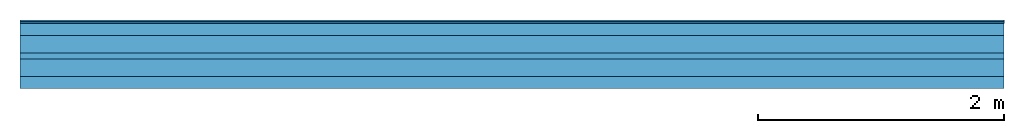
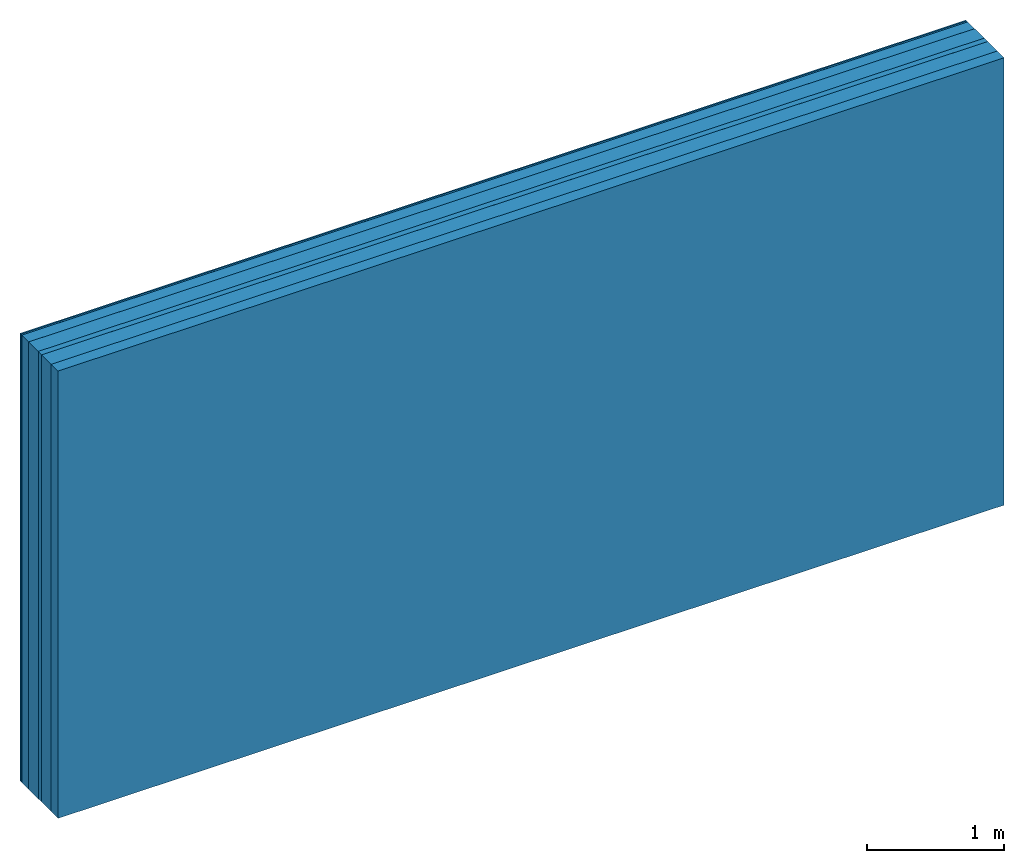
# One storey: 5 plates, 2 members, 1 element without a shape of its own.
"""IFC4 building model written with IfcOpenShell, lengths in metres."""

from ifc_helpers import new_model, si_unit, derived_unit, direction, frame, frame_2d, origin, origin_with_axes, place, context, project, spatial, rectangle, extrude, material, layer, layer_set, type_object, element, aggregate, save


model = new_model("IFC4")

# Units and contexts
plan_context = context("Plan", 3, precision=1e-05, world=origin(), true_north=direction((0.0, 1.0)))
model_context = context("Model", 3, precision=1e-05, world=origin(), true_north=direction((0.0, 1.0)))
ifc_project = project(units=[si_unit("LENGTHUNIT", "METRE"), derived_unit("SOUNDPRESSUREUNIT", [(si_unit("PRESSUREUNIT", "PASCAL", prefix="MICRO"), 0)]), si_unit("ENERGYUNIT", "JOULE", prefix="MEGA"), si_unit("MASSUNIT", "GRAM", prefix="KILO"), derived_unit("THERMALTRANSMITTANCEUNIT", [(si_unit("POWERUNIT", "WATT"), 1), (si_unit("AREAUNIT", "SQUARE_METRE"), -1), (si_unit("THERMODYNAMICTEMPERATUREUNIT", "KELVIN"), -1)]), derived_unit("AREADENSITYUNIT", [(si_unit("MASSUNIT", "GRAM", prefix="KILO"), 1), (si_unit("AREAUNIT", "SQUARE_METRE"), -1)]), derived_unit("USERDEFINED", [(si_unit("ENERGYUNIT", "JOULE", prefix="MEGA"), 1), (si_unit("AREAUNIT", "SQUARE_METRE"), -1)])], contexts=[plan_context, model_context])

# Site, building, storey
site = spatial("IfcSite", under=ifc_project)
building_placement = place(None, origin())
building = spatial("IfcBuilding", under=site, at=building_placement)
storey_placement = place(building_placement, origin())
storey = spatial("IfcBuildingStorey", under=building, at=storey_placement)

# Wall, members, plates
ifc_material_1 = material(Category="03.008")
ifc_layer_1 = layer(ifc_material_1, 0.0125, Name="room side 2nd layer")
ifc_material_2 = material(Name="Phone Star TRI", Category="03.013")
ifc_layer_2 = layer(ifc_material_2, 0.015, Name="room side 1st layer")
ifc_layer_3 = layer(None, 0.1, Name="Support")
ifc_material_3 = material(Name="of the art")
ifc_layer_4 = layer(ifc_material_3, 0.0, Name="Bond")
ifc_material_4 = material(Category="10.008")
ifc_layer_5 = layer(ifc_material_4, 0.14, Name="Intermediate insulation")
ifc_material_5 = material(Name="Air")
ifc_layer_6 = layer(ifc_material_5, 0.05, Name="Air gap")
ifc_layer_7 = layer(ifc_material_4, 0.14, Name="Intermediate insulation")
ifc_layer_8 = layer(ifc_material_3, 0.0, Name="Bond")
ifc_layer_9 = layer(None, 0.1, Name="Support")
ifc_layer_set = layer_set([ifc_layer_1, ifc_layer_2, ifc_layer_3, ifc_layer_4, ifc_layer_5, ifc_layer_6, ifc_layer_7, ifc_layer_8, ifc_layer_9])
wall_type = type_object("IfcWallType", Name="B9394", PredefinedType="NOTDEFINED", material=ifc_layer_set)
wall_placement = place(None, frame((0.0, 0.0, 0.0), z_axis=(0.0, -1.0, 0.0), x_axis=(1.0, 0.0, 0.0)))
wall = element("IfcWall", 1, at=wall_placement, inside=storey, type_object=wall_type, material=ifc_layer_set, Name="Wall #1")
ifc_material_6 = material(Name="OSB")
member_1_placement = place(wall_placement, origin())
member_1 = element("IfcMember", 2, at=member_1_placement, material=ifc_material_6, Name="Support", context=plan_context, shape_type="SweptSolid", body=[
    extrude(rectangle(XDim=1.0, YDim=0.1, at=frame_2d((0.5, 0.05), x_axis=(1.0, 0.0))), frame((0.0, 4.0, 0.0275), z_axis=(0.0, -1.0, 0.0), x_axis=(1.0, 0.0, 0.0)), (0.0, 0.0, 1.0), 4.0),
    extrude(rectangle(XDim=1.0, YDim=0.1, at=frame_2d((0.5, 0.05), x_axis=(1.0, 0.0))), frame((1.0, 4.0, 0.0275), z_axis=(0.0, -1.0, 0.0), x_axis=(1.0, 0.0, 0.0)), (0.0, 0.0, 1.0), 4.0),
    extrude(rectangle(XDim=1.0, YDim=0.1, at=frame_2d((0.5, 0.05), x_axis=(1.0, 0.0))), frame((2.0, 4.0, 0.0275), z_axis=(0.0, -1.0, 0.0), x_axis=(1.0, 0.0, 0.0)), (0.0, 0.0, 1.0), 4.0),
    extrude(rectangle(XDim=1.0, YDim=0.1, at=frame_2d((0.5, 0.05), x_axis=(1.0, 0.0))), frame((3.0, 4.0, 0.0275), z_axis=(0.0, -1.0, 0.0), x_axis=(1.0, 0.0, 0.0)), (0.0, 0.0, 1.0), 4.0),
    extrude(rectangle(XDim=1.0, YDim=0.1, at=frame_2d((0.5, 0.05), x_axis=(1.0, 0.0))), frame((4.0, 4.0, 0.0275), z_axis=(0.0, -1.0, 0.0), x_axis=(1.0, 0.0, 0.0)), (0.0, 0.0, 1.0), 4.0),
    extrude(rectangle(XDim=1.0, YDim=0.1, at=frame_2d((0.5, 0.05), x_axis=(1.0, 0.0))), frame((5.0, 4.0, 0.0275), z_axis=(0.0, -1.0, 0.0), x_axis=(1.0, 0.0, 0.0)), (0.0, 0.0, 1.0), 4.0),
    extrude(rectangle(XDim=1.0, YDim=0.1, at=frame_2d((0.5, 0.05), x_axis=(1.0, 0.0))), frame((6.0, 4.0, 0.0275), z_axis=(0.0, -1.0, 0.0), x_axis=(1.0, 0.0, 0.0)), (0.0, 0.0, 1.0), 4.0),
    extrude(rectangle(XDim=1.0, YDim=0.1, at=frame_2d((0.5, 0.05), x_axis=(1.0, 0.0))), frame((7.0, 4.0, 0.0275), z_axis=(0.0, -1.0, 0.0), x_axis=(1.0, 0.0, 0.0)), (0.0, 0.0, 1.0), 4.0),
])
member_2_placement = place(wall_placement, origin())
member_2 = element("IfcMember", 3, at=member_2_placement, material=ifc_material_6, Name="Support", context=plan_context, shape_type="SweptSolid", body=[
    extrude(rectangle(XDim=1.0, YDim=0.1, at=frame_2d((0.5, 0.05), x_axis=(1.0, 0.0))), frame((0.0, 4.0, 0.4575), z_axis=(0.0, -1.0, 0.0), x_axis=(1.0, 0.0, 0.0)), (0.0, 0.0, 1.0), 4.0),
    extrude(rectangle(XDim=1.0, YDim=0.1, at=frame_2d((0.5, 0.05), x_axis=(1.0, 0.0))), frame((1.0, 4.0, 0.4575), z_axis=(0.0, -1.0, 0.0), x_axis=(1.0, 0.0, 0.0)), (0.0, 0.0, 1.0), 4.0),
    extrude(rectangle(XDim=1.0, YDim=0.1, at=frame_2d((0.5, 0.05), x_axis=(1.0, 0.0))), frame((2.0, 4.0, 0.4575), z_axis=(0.0, -1.0, 0.0), x_axis=(1.0, 0.0, 0.0)), (0.0, 0.0, 1.0), 4.0),
    extrude(rectangle(XDim=1.0, YDim=0.1, at=frame_2d((0.5, 0.05), x_axis=(1.0, 0.0))), frame((3.0, 4.0, 0.4575), z_axis=(0.0, -1.0, 0.0), x_axis=(1.0, 0.0, 0.0)), (0.0, 0.0, 1.0), 4.0),
    extrude(rectangle(XDim=1.0, YDim=0.1, at=frame_2d((0.5, 0.05), x_axis=(1.0, 0.0))), frame((4.0, 4.0, 0.4575), z_axis=(0.0, -1.0, 0.0), x_axis=(1.0, 0.0, 0.0)), (0.0, 0.0, 1.0), 4.0),
    extrude(rectangle(XDim=1.0, YDim=0.1, at=frame_2d((0.5, 0.05), x_axis=(1.0, 0.0))), frame((5.0, 4.0, 0.4575), z_axis=(0.0, -1.0, 0.0), x_axis=(1.0, 0.0, 0.0)), (0.0, 0.0, 1.0), 4.0),
    extrude(rectangle(XDim=1.0, YDim=0.1, at=frame_2d((0.5, 0.05), x_axis=(1.0, 0.0))), frame((6.0, 4.0, 0.4575), z_axis=(0.0, -1.0, 0.0), x_axis=(1.0, 0.0, 0.0)), (0.0, 0.0, 1.0), 4.0),
    extrude(rectangle(XDim=1.0, YDim=0.1, at=frame_2d((0.5, 0.05), x_axis=(1.0, 0.0))), frame((7.0, 4.0, 0.4575), z_axis=(0.0, -1.0, 0.0), x_axis=(1.0, 0.0, 0.0)), (0.0, 0.0, 1.0), 4.0),
])
plate_1_placement = place(wall_placement, origin())
plate_1 = element("IfcPlate", 4, at=plate_1_placement, material=ifc_material_1, Name="room side 2nd layer", context=plan_context, shape_type="SweptSolid", body=[
    extrude(rectangle(XDim=8.0, YDim=4.0, at=frame_2d((4.0, 2.0), x_axis=(1.0, 0.0))), origin_with_axes(), (0.0, 0.0, 1.0), 0.0125),
])
plate_2_placement = place(wall_placement, origin())
plate_2 = element("IfcPlate", 5, at=plate_2_placement, material=ifc_material_2, Name="room side 1st layer", context=plan_context, shape_type="SweptSolid", body=[
    extrude(rectangle(XDim=8.0, YDim=4.0, at=frame_2d((4.0, 2.0), x_axis=(1.0, 0.0))), frame((0.0, 0.0, 0.0125), z_axis=(0.0, 0.0, 1.0), x_axis=(1.0, 0.0, 0.0)), (0.0, 0.0, 1.0), 0.015),
])
plate_3_placement = place(wall_placement, origin())
plate_3 = element("IfcPlate", 6, at=plate_3_placement, material=ifc_material_4, Name="Intermediate insulation", context=plan_context, shape_type="SweptSolid", body=[
    extrude(rectangle(XDim=8.0, YDim=4.0, at=frame_2d((4.0, 2.0), x_axis=(1.0, 0.0))), frame((0.0, 0.0, 0.1275), z_axis=(0.0, 0.0, 1.0), x_axis=(1.0, 0.0, 0.0)), (0.0, 0.0, 1.0), 0.14),
])
plate_4_placement = place(wall_placement, origin())
plate_4 = element("IfcPlate", 7, at=plate_4_placement, material=ifc_material_5, Name="Air gap", context=plan_context, shape_type="SweptSolid", body=[
    extrude(rectangle(XDim=8.0, YDim=4.0, at=frame_2d((4.0, 2.0), x_axis=(1.0, 0.0))), frame((0.0, 0.0, 0.2675), z_axis=(0.0, 0.0, 1.0), x_axis=(1.0, 0.0, 0.0)), (0.0, 0.0, 1.0), 0.05),
])
plate_5_placement = place(wall_placement, origin())
plate_5 = element("IfcPlate", 8, at=plate_5_placement, material=ifc_material_4, Name="Intermediate insulation", context=plan_context, shape_type="SweptSolid", body=[
    extrude(rectangle(XDim=8.0, YDim=4.0, at=frame_2d((4.0, 2.0), x_axis=(1.0, 0.0))), frame((0.0, 0.0, 0.3175), z_axis=(0.0, 0.0, 1.0), x_axis=(1.0, 0.0, 0.0)), (0.0, 0.0, 1.0), 0.14),
])
aggregate(wall, [plate_1, plate_2, member_1, plate_3, plate_4, plate_5, member_2])

save(model, "model.ifc")
